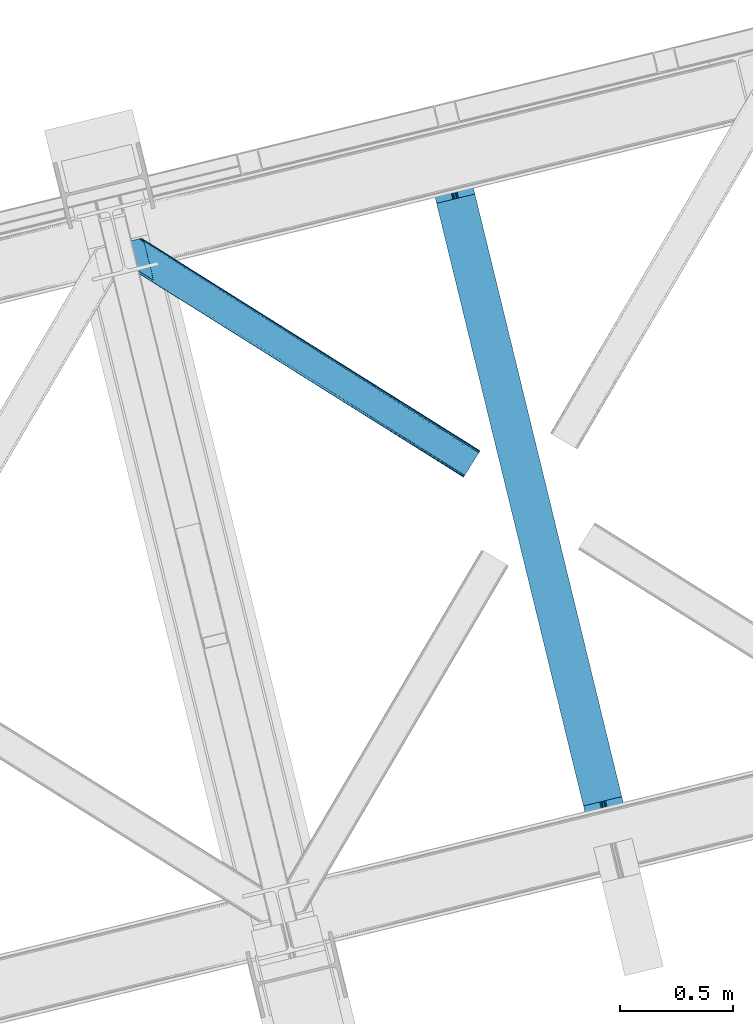
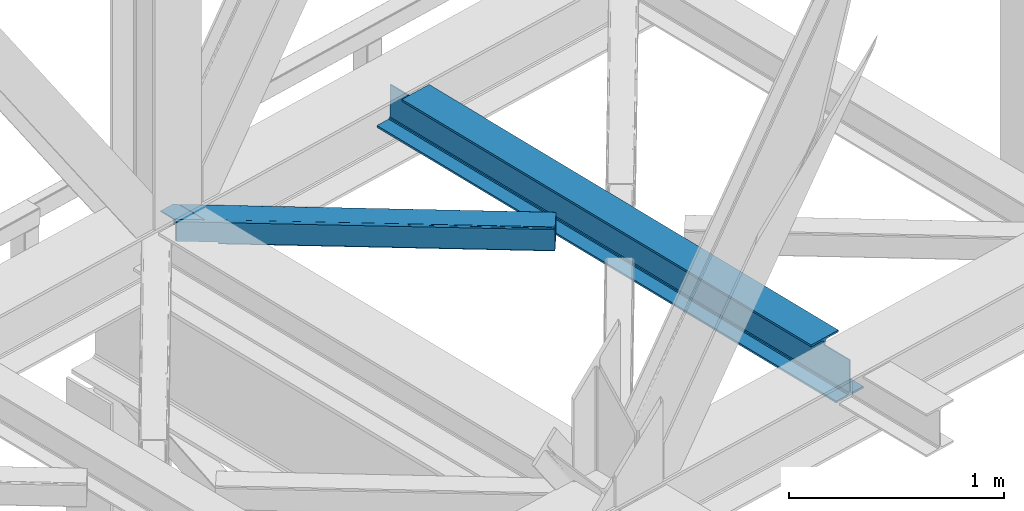
# One storey, part 31 of 93: 1 beam, 1 member.
"""IFC4 building model written with IfcOpenShell, lengths in millimetres."""

from ifc_helpers import new_model, entity, si_unit, converted_unit, derived_unit, direction, frame, origin, place, context, subcontext, project, spatial, triangles, polygons, material, type_object, element, save


model = new_model("IFC4")

# Units and contexts
model_context = context("Model", 3, precision=0.01, world=origin(), true_north=direction((6.12303176911189e-17, 1.0)))
plan_context = context("Plan", 3, precision=0.01, world=origin(), true_north=direction((6.12303176911189e-17, 1.0)))
body_context = subcontext(model_context, "Body", "Model", "MODEL_VIEW")
ifc_project = project(units=[si_unit("LENGTHUNIT", "METRE", prefix="MILLI"), si_unit("AREAUNIT", "SQUARE_METRE"), si_unit("VOLUMEUNIT", "CUBIC_METRE"), converted_unit("PLANEANGLEUNIT", "DEGREE", entity("IfcRatioMeasure", 0.0174532925199433), si_unit("PLANEANGLEUNIT", "RADIAN"), dimensions=[0, 0, 0, 0, 0, 0, 0]), si_unit("MASSUNIT", "GRAM", prefix="KILO"), derived_unit("MASSDENSITYUNIT", [(si_unit("MASSUNIT", "GRAM", prefix="KILO"), 1), (si_unit("LENGTHUNIT", "METRE"), -3)]), derived_unit("MOMENTOFINERTIAUNIT", [(si_unit("LENGTHUNIT", "METRE"), 4)]), si_unit("TIMEUNIT", "SECOND"), si_unit("FREQUENCYUNIT", "HERTZ"), si_unit("THERMODYNAMICTEMPERATUREUNIT", "DEGREE_CELSIUS"), derived_unit("THERMALTRANSMITTANCEUNIT", [(si_unit("MASSUNIT", "GRAM", prefix="KILO"), 1), (si_unit("THERMODYNAMICTEMPERATUREUNIT", "KELVIN"), -1), (si_unit("TIMEUNIT", "SECOND"), -3)]), derived_unit("VOLUMETRICFLOWRATEUNIT", [(si_unit("LENGTHUNIT", "METRE"), 3), (si_unit("TIMEUNIT", "SECOND"), -1)]), derived_unit("MASSFLOWRATEUNIT", [(si_unit("MASSUNIT", "GRAM", prefix="KILO"), 1), (si_unit("TIMEUNIT", "SECOND"), -1)]), derived_unit("ROTATIONALFREQUENCYUNIT", [(si_unit("TIMEUNIT", "SECOND"), -1)]), si_unit("ELECTRICCURRENTUNIT", "AMPERE"), si_unit("ELECTRICVOLTAGEUNIT", "VOLT"), si_unit("POWERUNIT", "WATT"), si_unit("FORCEUNIT", "NEWTON", prefix="KILO"), si_unit("ILLUMINANCEUNIT", "LUX"), si_unit("LUMINOUSFLUXUNIT", "LUMEN"), si_unit("LUMINOUSINTENSITYUNIT", "CANDELA"), derived_unit("USERDEFINED", [(si_unit("MASSUNIT", "GRAM", prefix="KILO"), -1), (si_unit("LENGTHUNIT", "METRE"), -2), (si_unit("TIMEUNIT", "SECOND"), 3), (si_unit("LUMINOUSFLUXUNIT", "LUMEN"), 1)]), derived_unit("LINEARVELOCITYUNIT", [(si_unit("LENGTHUNIT", "METRE"), 1), (si_unit("TIMEUNIT", "SECOND"), -1)]), si_unit("PRESSUREUNIT", "PASCAL"), derived_unit("USERDEFINED", [(si_unit("LENGTHUNIT", "METRE"), -2), (si_unit("MASSUNIT", "GRAM", prefix="KILO"), 1), (si_unit("TIMEUNIT", "SECOND"), -2)]), derived_unit("LINEARFORCEUNIT", [(si_unit("MASSUNIT", "GRAM", prefix="KILO"), 1), (si_unit("LENGTHUNIT", "METRE"), 1), (si_unit("TIMEUNIT", "SECOND"), -2), (si_unit("LENGTHUNIT", "METRE"), -1)]), derived_unit("PLANARFORCEUNIT", [(si_unit("MASSUNIT", "GRAM", prefix="KILO"), 1), (si_unit("LENGTHUNIT", "METRE"), 1), (si_unit("TIMEUNIT", "SECOND"), -2), (si_unit("LENGTHUNIT", "METRE"), -2)])], contexts=[model_context, plan_context])

# Site, building, storey
site_placement = place(None, origin())
site = spatial("IfcSite", under=ifc_project, at=site_placement, CompositionType="ELEMENT")
building_placement = place(site_placement, origin())
building = spatial("IfcBuilding", under=site, at=building_placement, CompositionType="ELEMENT")
storey_placement = place(building_placement, frame((0.0, 0.0, 15900.0)))
storey = spatial("IfcBuildingStorey", under=building, at=storey_placement, CompositionType="ELEMENT", Elevation=15900.0)

# Beam
ifc_material = material(Name="Metal painted (White)")
beam_type = type_object("IfcBeamType", PredefinedType="BEAM")
beam_placement = place(storey_placement, frame((-53806.5764909468, 4670.78252188338, 3441.0)))
element("IfcBeam", 1, at=beam_placement, inside=storey, type_object=beam_type, material=ifc_material, ObjectType="Steel Beam", PredefinedType="BEAM", context=body_context, shape_type="Tessellation", body=[
    polygons([(900.985346189432, 41.4445662733081, 11.000000000004), (900.985346189432, 41.4445662733081, 2.16573425859679e-12), (170.021610174752, 3040.13999372697, 2.16573425859679e-12), (170.021610174752, 3040.13999372697, 11.000000000004), (834.919806235814, 25.3403919499656, 11.000000000004), (103.956070221144, 3024.03581940362, 11.000000000004), (828.971056214531, 23.8903211957396, 12.2179274798217), (98.0073201998513, 3022.5857486494, 12.2179274798217), (823.927949458422, 22.66101056892, 15.6862915010192), (92.9642134437427, 3021.35643802258, 15.6862915010192), (820.558253255246, 21.8396114687119, 20.8770650821657), (89.5945172405668, 3020.53503892237, 20.8770650821657), (819.374973305552, 21.5511744621206, 27.0000000000047), (88.4112372908809, 3020.24660191578, 27.0000000000047), (81.6103728838888, 3018.58881926485, 27.0000000000047), (81.6103728838888, 3018.58881926485, 203.000000000006), (88.4112372908723, 3020.24660191578, 203.000000000006), (-8.66293703438714e-12, 2998.69542745366, 2.16573425859679e-12), (8.66293703438714e-12, 2998.69542745366, 10.9999999999997), (66.0655399536259, 3014.799601777, 11.000000000004), (72.0142899749184, 3016.24967253123, 12.2179274798217), (77.0573967310357, 3017.47898315805, 15.6862915010192), (80.4270929342029, 3018.30038225826, 20.8770650821657), (819.374973305552, 21.5511744621206, 203.000000000006), (812.574108898559, 19.8933918111881, 203.000000000006), (812.574108898559, 19.8933918111881, 27.0000000000047), (811.390828948873, 19.6049548045968, 20.8770650821657), (808.021132745698, 18.7835557043887, 15.6862915010192), (802.978025989598, 17.5542450775691, 12.2179274798217), (797.029275968305, 16.1041743233431, 11.000000000004), (730.963736014671, 0.0, 10.9999999999997), (730.963736014671, 0.0, 2.16573425859679e-12), (779.675212882749, 184.415062601692, 203.069791966819), (128.020401343504, 2857.75452019162, 203.000000000006), (128.243282132658, 2856.8401777572, 203.617301946336), (128.256196377177, 2856.7871977843, 217.000003693143), (779.530009633833, 185.010597404072, 217.000003676718), (779.530880241722, 185.007025963192, 204.00000679514), (772.96491171832, 182.385463974442, 203.006342981529), (772.742064056782, 183.299815969774, 203.617301946336), (772.729149812254, 183.352795942667, 217.000003693143), (121.455336555608, 2855.1293963229, 217.000003676718), (121.454465947718, 2855.13296776377, 204.00000679514), (121.310166358664, 2855.72494066435, 203.076120467494), (121.219536936511, 2856.09673754069, 203.000000000006), (780.71349435786, 185.298194377514, 223.122939328039), (784.082490766547, 186.122464201395, 228.313710402595), (789.125126170563, 187.353708426699, 231.782072735464), (795.073705041266, 188.804481281381, 232.999999602236), (861.139155906781, 204.909021065315, 232.999999283132), (861.137682570352, 204.915065042188, 243.999994005812), (691.11630166644, 163.469558245298, 243.999994827032), (691.117775002877, 163.463514268424, 233.000000104353), (757.183225868401, 179.568054052359, 232.999999785253), (763.132130996722, 181.017488520583, 231.782072861016), (768.175695503862, 182.244921343718, 228.313710479427), (771.546082413593, 183.063487001147, 223.12293937232), (120.271851831572, 2854.84179934945, 223.122939328039), (116.902855422901, 2854.01752952557, 228.313710402595), (111.860220018877, 2852.78628530027, 231.782072735464), (105.911641148174, 2851.33551244559, 232.999999602236), (39.8461902826505, 2835.23097266165, 232.999999283128), (39.8476636190881, 2835.22492868478, 243.999994005812), (209.869044523001, 2876.67043548167, 243.999994827032), (209.867571186563, 2876.67647945854, 233.000000104357), (143.80212032104, 2860.57193967461, 232.999999785253), (137.853215192718, 2859.12250520639, 231.782072861012), (132.809650685587, 2857.89507238325, 228.313710479427), (129.439263775847, 2857.07650672582, 223.12293937232)], [[[1, 2, 3, 4]], [[5, 1, 4, 6]], [[7, 5, 6, 8]], [[9, 7, 8, 10]], [[11, 9, 10, 12]], [[13, 11, 12, 14]], [[15, 16, 17, 14, 12, 10, 8, 6, 4, 3, 18, 19, 20, 21, 22, 23]], [[13, 24, 25, 26, 27, 28, 29, 30, 31, 32, 2, 1, 5, 7, 9, 11]], [[2, 32, 18, 3]], [[32, 31, 19, 18]], [[31, 30, 20, 19]], [[27, 26, 15, 23]], [[28, 27, 23, 22]], [[29, 28, 22, 21]], [[30, 29, 21, 20]], [[33, 24, 13, 14, 17, 34, 35, 36, 37, 38]], [[25, 39, 40, 41, 42, 43, 44, 16, 15, 26]], [[39, 25, 24, 33]], [[45, 34, 17, 16]], [[41, 40, 38, 37, 46, 47, 48, 49, 50, 51, 52, 53, 54, 55, 56, 57]], [[42, 58, 59, 60, 61, 62, 63, 64, 65, 66, 67, 68, 69, 36, 35, 43]], [[46, 37, 36, 69]], [[47, 46, 69, 68]], [[48, 47, 68, 67]], [[49, 48, 67, 66]], [[50, 49, 66, 65]], [[51, 50, 65, 64]], [[52, 51, 64, 63]], [[53, 52, 63, 62]], [[54, 53, 62, 61]], [[55, 54, 61, 60]], [[56, 55, 60, 59]], [[57, 56, 59, 58]], [[41, 57, 58, 42]]], closed=False),
])

# Member
member_type = type_object("IfcMemberType", PredefinedType="BRACE")
member_placement = place(storey_placement, frame((-55162.1911010742, 6291.04972229004, 3511.0000579834)))
element("IfcMember", 2, at=member_placement, inside=storey, type_object=member_type, ObjectType="Steel Horizontal Brace", PredefinedType="BRACE", context=body_context, shape_type="Tessellation", body=[
    triangles([(207.722204589845, 841.064360046386, 0.0), (172.045312499999, 987.426937866211, 0.0), (1579.92216796875, 103.755294799805, 0.0), (1524.10231933594, 14.8217697143555, 0.0), (1589.22392578125, 118.577645874023, 17.5000946044929), (1588.5169921875, 117.449226379395, 10.8028289794929), (166.547973632813, 1009.96393432617, 10.8028289794929), (166.096838378908, 1011.82079772949, 17.5000946044929), (1586.49851074219, 114.236050415039, 5.12526855468968), (167.840917968751, 1004.67646636963, 5.12526855468968), (1583.48474121094, 109.42762298584, 1.33247680664135), (169.766381835936, 996.762414550781, 1.33247680664135), (1520.53974609375, 9.15002288818323, 1.33247680664135), (202.587634277341, 836.378599548339, 1.33247680664135), (208.512854003908, 837.822697448731, 0.155804443362285), (1517.5259765625, 4.34101409912091, 5.12526855468968), (194.895080566406, 834.503713989257, 5.12526855468968), (1515.50749511718, 1.12783813476563, 10.8028289794929), (189.755859375, 833.250883483886, 10.8028289794929), (1514.80056152344, 0.0, 17.5000946044929), (187.951318359374, 832.810794067383, 17.5000946044929), (204.382873535156, 836.815782165527, 12.1260040283232), (208.512854003908, 837.822697448731, 9.69243164062573), (199.652929687501, 835.662945556641, 17.9802978515654), (198.425097656247, 835.364126586914, 19.4999725341804), (187.951318359374, 832.810794067383, 19.4999725341804), (25.310083007811, 934.894679260254, 19.4999725341804), (22.6823364257798, 945.669602966308, 19.4999725341804), (1514.80056152344, 0.0, 122.500662231447), (25.310083007811, 934.894679260254, 122.500662231447), (1527.82302246094, 20.7510589599606, 6.99957275390625), (205.340954589839, 850.821903991699, 6.99957275390625), (207.559423828126, 841.724203491211, 8.88434143066479), (1524.26510009765, 15.0787307739256, 8.3320495605476), (1521.2466796875, 10.2697219848633, 12.1260040283232), (1519.22819824218, 7.05654602050799, 17.8035644531265), (1518.52126464844, 5.92870788574237, 24.4996673583992), (22.9334838867144, 944.652223205566, 24.4996673583992), (174.421911621095, 977.669393920898, 6.99957275390625), (1576.20146484375, 97.8260055541987, 6.99957275390625), (168.971081542964, 1000.03372650147, 17.8803039550803), (170.217517089841, 994.918341064453, 12.1260040283232), (172.147631835935, 987.004870605469, 8.3320495605476), (168.836206054686, 1000.58485565185, 18.5000335693367), (166.096838378908, 1011.82079772949, 18.5000335693367), (1518.52126464844, 5.92870788574237, 115.501089477541), (22.9334838867144, 944.652223205566, 115.501089477541), (1527.82302246094, 20.7510589599606, 133.000021362306), (1524.26510009765, 15.0787307739256, 131.667544555665), (19.2592895507769, 959.71118774414, 131.667544555665), (16.9850097656235, 969.046083068847, 133.000021362306), (1521.2466796875, 10.2697219848633, 127.87475280762), (21.1894042968706, 951.797135925292, 127.87475280762), (1519.22819824218, 7.05654602050799, 122.196029663086), (22.4776977539077, 946.509086608887, 122.196029663086), (168.515295410158, 1000.87902374268, 18.7407165527366), (165.808483886714, 1012.00101928711, 18.736065673831), (168.171130371091, 1001.19702758789, 19.0000030517585), (165.492224121095, 1012.2021697998, 19.0000030517585), (167.826965332031, 1001.5150314331, 19.2592895507842), (165.17131347656, 1012.4033203125, 19.2639404296897), (167.510705566405, 1001.80919952393, 19.4999725341804), (164.882958984374, 1012.58354187012, 19.4999725341804), (78.2975463867188, 1057.80461883545, 19.4999725341804), (88.7666748046831, 1060.35795135498, 19.4999725341804), (24.8589477539063, 936.751542663574, 129.197927856447), (23.5706542968765, 942.040173339844, 134.874325561526), (22.1242309570298, 947.964811706543, 137.999716186525), (0.0, 1038.71973724365, 137.999716186525), (0.0, 1038.71973724365, 133.000021362306), (1589.22392578125, 118.577645874023, 122.500662231447), (88.7666748046831, 1060.35795135498, 122.500662231447), (1584.7962890625, 111.520518493652, 17.8035644531265), (1585.50322265625, 112.648356628418, 24.4996673583992), (79.2835327148423, 1058.04588317871, 24.4996673583992), (1579.75938720703, 103.498333740235, 8.3320495605476), (1582.77780761719, 108.307342529297, 12.1260040283232), (64.647216796875, 1054.47807769775, 131.667544555665), (55.5733520507783, 1052.26600341797, 133.000021362306), (76.0651245117188, 1057.26104736328, 137.999716186525), (81.8229125976577, 1058.66503143311, 134.874325561526), (72.3397705078096, 1056.35296325684, 127.87475280762), (77.4789916992158, 1057.60579376221, 122.196029663086), (86.962133789064, 1059.91786193848, 129.197927856447), (79.2835327148423, 1058.04588317871, 115.501089477541), (1576.20146484375, 97.8260055541987, 133.000021362306), (1585.50322265625, 112.648356628418, 115.501089477541), (1584.7962890625, 111.520518493652, 122.196029663086), (1582.77780761719, 108.307342529297, 127.87475280762), (1579.75938720703, 103.498333740235, 131.667544555665), (1588.5169921875, 117.449226379395, 129.197927856447), (1586.49851074219, 114.236050415039, 134.874325561526), (1583.48474121094, 109.42762298584, 138.667117309571), (1579.92216796875, 103.755294799805, 139.999594116212), (1524.10231933594, 14.8217697143555, 139.999594116212), (1520.53974609375, 9.15002288818323, 138.667117309571), (1517.5259765625, 4.34101409912091, 134.874325561526), (1515.50749511718, 1.12783813476563, 129.197927856447), (98.1940063476577, 1043.37177886963, 137.999716186525), (139.391491699214, 874.36000213623, 137.999716186525), (137.847399902341, 884.922148132324, 139.999594116212), (139.828674316406, 876.794155883789, 138.999655151369), (140.051916503908, 875.629692077637, 138.667117309571), (139.805419921875, 874.273379516601, 138.076455688479), (139.921691894531, 874.907643127442, 138.353182983399), (98.7102539062471, 1042.87471618652, 138.076455688479), (99.6032226562456, 1040.78589019775, 138.634561157229), (99.1985961914033, 1041.72304229736, 138.383413696291), (100.189233398436, 1039.41271820068, 138.999655151369), (102.170507812501, 1031.28472595215, 139.999594116212), (140.037963867188, 875.543650817871, 138.629910278323)], [[1, 2, 3], [3, 4, 1], [5, 6, 7], [7, 8, 5], [6, 9, 10], [10, 7, 6], [9, 11, 12], [12, 10, 9], [11, 3, 2], [2, 12, 11], [13, 14, 15], [15, 4, 13], [15, 1, 4], [13, 16, 14], [17, 14, 16], [16, 18, 17], [19, 17, 18], [18, 20, 19], [21, 19, 20], [22, 23, 14], [22, 14, 17], [17, 19, 24], [23, 15, 14], [24, 22, 17], [19, 21, 25], [26, 25, 21], [19, 25, 24], [27, 28, 25], [25, 26, 27], [26, 29, 30], [20, 26, 21], [26, 20, 29], [26, 30, 27], [31, 32, 33], [34, 33, 23], [23, 35, 34], [23, 22, 35], [36, 35, 22], [37, 36, 24], [24, 25, 37], [37, 25, 38], [28, 38, 25], [22, 24, 36], [33, 34, 31], [39, 32, 40], [31, 40, 32], [41, 7, 10], [10, 42, 41], [12, 42, 10], [42, 12, 43], [7, 44, 8], [45, 8, 44], [7, 41, 44], [43, 12, 2], [33, 32, 1], [1, 39, 2], [39, 1, 32], [15, 33, 1], [39, 43, 2], [23, 33, 15], [46, 37, 38], [38, 47, 46], [48, 49, 50], [50, 51, 48], [49, 52, 53], [53, 50, 49], [52, 54, 55], [55, 53, 52], [54, 46, 47], [47, 55, 54], [45, 44, 56], [56, 57, 45], [57, 56, 58], [58, 59, 57], [59, 58, 60], [60, 61, 59], [61, 60, 62], [62, 63, 61], [64, 65, 63], [63, 62, 64], [47, 27, 30], [66, 55, 30], [55, 66, 67], [55, 47, 30], [38, 27, 47], [28, 27, 38], [53, 55, 67], [68, 51, 50], [51, 68, 69], [69, 70, 51], [50, 53, 68], [68, 53, 67], [5, 45, 71], [8, 45, 5], [45, 72, 71], [72, 45, 57], [72, 57, 59], [59, 61, 72], [63, 72, 61], [72, 63, 65], [73, 41, 42], [74, 75, 62], [62, 73, 74], [56, 73, 58], [56, 44, 73], [73, 60, 58], [73, 62, 60], [44, 41, 73], [75, 64, 62], [40, 76, 39], [43, 39, 76], [76, 77, 43], [42, 43, 77], [42, 77, 73], [78, 79, 80], [81, 82, 80], [78, 80, 82], [83, 81, 84], [79, 69, 80], [79, 70, 69], [83, 82, 81], [72, 85, 83], [85, 72, 65], [75, 65, 64], [65, 75, 85], [72, 83, 84], [51, 79, 86], [79, 51, 70], [86, 48, 51], [74, 87, 75], [85, 75, 87], [87, 88, 85], [83, 85, 88], [88, 89, 83], [82, 83, 89], [89, 90, 82], [78, 82, 90], [90, 86, 78], [79, 78, 86], [91, 89, 88], [87, 5, 71], [91, 88, 71], [91, 92, 89], [88, 87, 71], [89, 92, 93], [86, 94, 95], [94, 90, 93], [90, 94, 86], [90, 89, 93], [6, 77, 9], [74, 5, 87], [5, 73, 6], [73, 5, 74], [6, 73, 77], [3, 40, 4], [11, 9, 77], [77, 76, 11], [76, 40, 3], [3, 11, 76], [52, 96, 97], [95, 48, 86], [95, 49, 48], [49, 95, 96], [52, 49, 96], [46, 29, 20], [98, 54, 52], [97, 98, 52], [54, 98, 29], [46, 54, 29], [13, 35, 16], [4, 40, 31], [31, 34, 4], [34, 35, 13], [13, 4, 34], [18, 16, 35], [20, 37, 46], [36, 20, 18], [20, 36, 37], [36, 18, 35], [80, 68, 99], [80, 69, 68], [100, 99, 68], [95, 101, 102], [102, 96, 95], [102, 103, 96], [97, 104, 100], [100, 67, 97], [100, 68, 67], [96, 105, 104], [96, 103, 105], [104, 97, 96], [29, 98, 30], [66, 30, 98], [98, 97, 66], [67, 66, 97], [92, 81, 106], [106, 93, 92], [107, 93, 108], [106, 108, 93], [81, 80, 99], [107, 94, 93], [107, 109, 94], [109, 110, 94], [92, 91, 84], [84, 81, 92], [91, 71, 72], [72, 84, 91], [110, 101, 94], [95, 94, 101], [111, 102, 109], [109, 107, 111], [107, 108, 104], [108, 106, 104], [110, 109, 101], [102, 101, 109]]),
])

save(model, "model.ifc")
